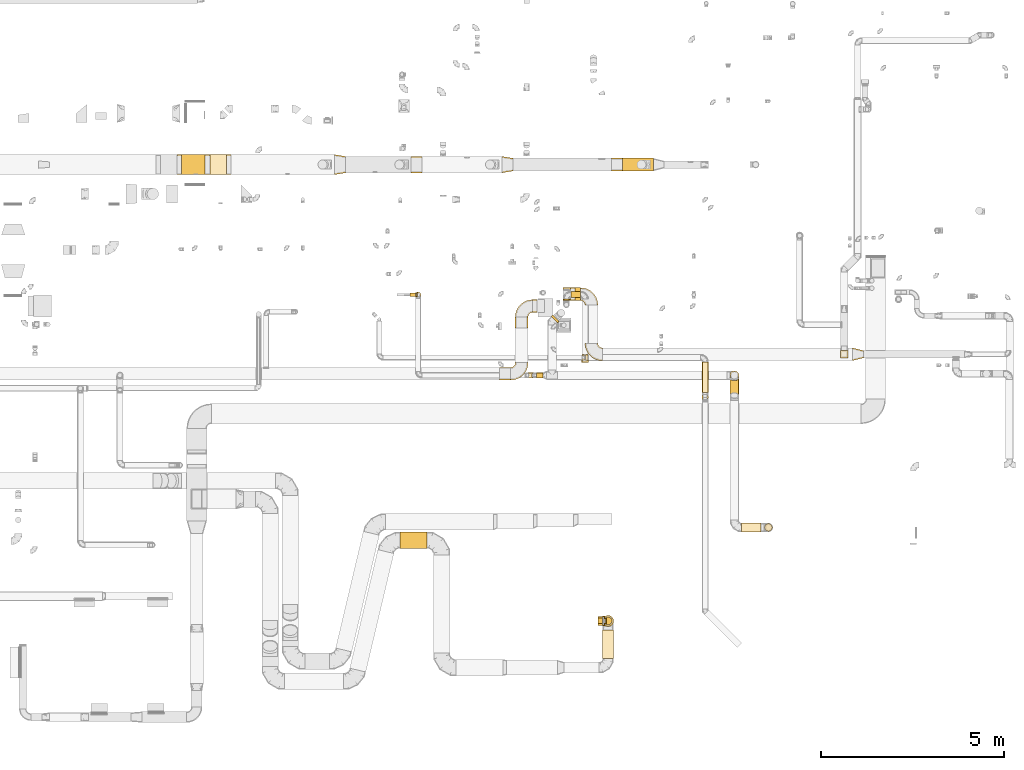
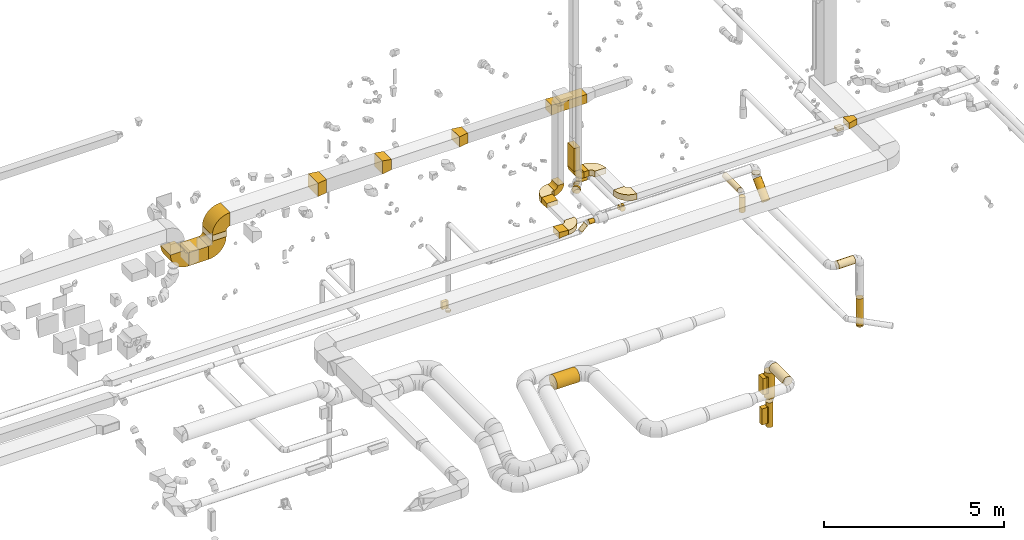
# One storey, part 8 of 97: 49 coverings.
"""IFC2X3 building model written with IfcOpenShell, lengths in millimetres."""

from ifc_helpers import new_model, entity, si_unit, converted_unit, derived_unit, direction, frame, frame_2d, origin, origin_2d_with_axis, place, context, subcontext, project, spatial, polyline, circle_curve, parameter, trimmed, segment, composite_curve, rectangle, circle, outline, extrude, element, save


model = new_model("IFC2X3")

# Units and contexts
model_context = context("Model", 3, precision=0.01, world=origin(), true_north=direction((6.12303176911189e-17, 1.0)))
body_context = subcontext(model_context, "Body", "Model", "MODEL_VIEW")
ifc_project = project(units=[si_unit("LENGTHUNIT", "METRE", prefix="MILLI"), si_unit("AREAUNIT", "SQUARE_METRE"), si_unit("VOLUMEUNIT", "CUBIC_METRE"), converted_unit("PLANEANGLEUNIT", "DEGREE", entity("IfcRatioMeasure", 0.0174532925199433), si_unit("PLANEANGLEUNIT", "RADIAN"), dimensions=[0, 0, 0, 0, 0, 0, 0]), si_unit("MASSUNIT", "GRAM", prefix="KILO"), derived_unit("MASSDENSITYUNIT", [(si_unit("MASSUNIT", "GRAM", prefix="KILO"), 1), (si_unit("LENGTHUNIT", "METRE"), -3)]), derived_unit("MOMENTOFINERTIAUNIT", [(si_unit("LENGTHUNIT", "METRE"), 4)]), si_unit("TIMEUNIT", "SECOND"), si_unit("FREQUENCYUNIT", "HERTZ"), si_unit("THERMODYNAMICTEMPERATUREUNIT", "DEGREE_CELSIUS"), derived_unit("THERMALTRANSMITTANCEUNIT", [(si_unit("MASSUNIT", "GRAM", prefix="KILO"), 1), (si_unit("THERMODYNAMICTEMPERATUREUNIT", "KELVIN"), -1), (si_unit("TIMEUNIT", "SECOND"), -3)]), derived_unit("VOLUMETRICFLOWRATEUNIT", [(si_unit("LENGTHUNIT", "METRE"), 3), (si_unit("TIMEUNIT", "SECOND"), -1)]), derived_unit("MASSFLOWRATEUNIT", [(si_unit("MASSUNIT", "GRAM", prefix="KILO"), 1), (si_unit("TIMEUNIT", "SECOND"), -1)]), derived_unit("ROTATIONALFREQUENCYUNIT", [(si_unit("TIMEUNIT", "SECOND"), -1)]), si_unit("ELECTRICCURRENTUNIT", "AMPERE"), si_unit("ELECTRICVOLTAGEUNIT", "VOLT"), si_unit("POWERUNIT", "WATT"), si_unit("FORCEUNIT", "NEWTON", prefix="KILO"), si_unit("ILLUMINANCEUNIT", "LUX"), si_unit("LUMINOUSFLUXUNIT", "LUMEN"), si_unit("LUMINOUSINTENSITYUNIT", "CANDELA"), derived_unit("USERDEFINED", [(si_unit("MASSUNIT", "GRAM", prefix="KILO"), -1), (si_unit("LENGTHUNIT", "METRE"), -2), (si_unit("TIMEUNIT", "SECOND"), 3), (si_unit("LUMINOUSFLUXUNIT", "LUMEN"), 1)]), derived_unit("LINEARVELOCITYUNIT", [(si_unit("LENGTHUNIT", "METRE"), 1), (si_unit("TIMEUNIT", "SECOND"), -1)]), si_unit("PRESSUREUNIT", "PASCAL"), derived_unit("USERDEFINED", [(si_unit("LENGTHUNIT", "METRE"), -2), (si_unit("MASSUNIT", "GRAM", prefix="KILO"), 1), (si_unit("TIMEUNIT", "SECOND"), -2)]), derived_unit("LINEARFORCEUNIT", [(si_unit("MASSUNIT", "GRAM", prefix="KILO"), 1), (si_unit("LENGTHUNIT", "METRE"), 1), (si_unit("TIMEUNIT", "SECOND"), -2), (si_unit("LENGTHUNIT", "METRE"), -1)]), derived_unit("PLANARFORCEUNIT", [(si_unit("MASSUNIT", "GRAM", prefix="KILO"), 1), (si_unit("LENGTHUNIT", "METRE"), 1), (si_unit("TIMEUNIT", "SECOND"), -2), (si_unit("LENGTHUNIT", "METRE"), -2)])], contexts=[model_context])

# Site, building, storey
site_placement = place(None, origin())
site = spatial("IfcSite", under=ifc_project, at=site_placement, CompositionType="ELEMENT")
building_placement = place(site_placement, origin())
building = spatial("IfcBuilding", under=site, at=building_placement, CompositionType="ELEMENT")
storey_placement = place(building_placement, frame((0.0, 0.0, -4900.0)))
storey = spatial("IfcBuildingStorey", under=building, at=storey_placement, CompositionType="ELEMENT", Elevation=-4900.0)

# Coverings
covering_1_placement = place(storey_placement, frame((55013.15, 4871.73, 2723.4)))
element("IfcCovering", 1, at=covering_1_placement, inside=storey, PredefinedType="INSULATION", context=body_context, shape_type="SweptSolid", body=[
    extrude(circle(Radius=225.0, at=origin_2d_with_axis()), frame((0.0, 226.6, 226.6), z_axis=(1.0, 0.0, 0.0), x_axis=(0.0, 1.0, 0.0)), (0.0, 0.0, 1.0), 730.830177170377),
])
covering_2_placement = place(storey_placement, frame((60537.54, 1876.52, 2798.4)))
element("IfcCovering", 2, at=covering_2_placement, inside=storey, PredefinedType="INSULATION", context=body_context, shape_type="SweptSolid", body=[
    extrude(circle(Radius=150.0, at=origin_2d_with_axis()), frame((151.6, 0.0, 151.6), z_axis=(0.0, 1.0, 0.0), x_axis=(-1.0, 0.0, 0.0)), (0.0, -1.34405375717961e-09, 1.0), 771.024518339497),
])
covering_3_placement = place(storey_placement, frame((60582.54, 2790.95, 822.36)))
element("IfcCovering", 3, at=covering_3_placement, inside=storey, PredefinedType="INSULATION", context=body_context, shape_type="SweptSolid", body=[
    extrude(circle(Radius=105.0, at=origin_2d_with_axis()), frame((106.6, 106.6, 0.0), z_axis=(0.0, 0.0, 1.0), x_axis=(-1.0, 0.0, 0.0)), (0.0, 0.0, 1.0), 839.999998963608),
])
covering_4_placement = place(storey_placement, frame((60537.54, 2745.95, 1816.36)))
element("IfcCovering", 4, at=covering_4_placement, inside=storey, PredefinedType="INSULATION", context=body_context, shape_type="SweptSolid", body=[
    extrude(outline(polyline([(-19.58, -148.72), (19.58, -148.72), (57.4, -138.58), (91.31, -119.0), (119.0, -91.31), (138.58, -57.4), (148.72, -19.58), (148.72, 19.58), (138.58, 57.4), (119.0, 91.31), (91.31, 119.0), (57.4, 138.58), (19.58, 148.72), (-19.58, 148.72), (-57.4, 138.58), (-91.31, 119.0), (-119.0, 91.31), (-138.58, 57.4), (-148.72, 19.58), (-148.72, -19.58), (-138.58, -57.4), (-119.0, -91.31), (-91.31, -119.0), (-57.4, -138.58), (-19.58, -148.72)])), frame((151.6, 151.6, 0.0), z_axis=(0.0, -1.75949613054488e-09, 1.0), x_axis=(0.130526192220057, -0.99144486137381, -1.74444892770835e-09)), (0.0, 0.0, 1.0), 883.639712944482),
])
covering_5_placement = place(storey_placement, frame((60414.13, 2772.54, 2025.0)))
element("IfcCovering", 5, at=covering_5_placement, inside=storey, PredefinedType="INSULATION", context=body_context, shape_type="SweptSolid", body=[
    extrude(rectangle(XDim=129.999999999996, YDim=250.000000000001, at=origin_2d_with_axis()), frame((65.0, 125.0, 0.0), z_axis=(0.0, 0.0, 1.0), x_axis=(-1.0, 0.0, 0.0)), (0.0, 0.0, 1.0), 550.0),
])
covering_6_placement = place(storey_placement, frame((60414.13, 2822.54, 975.0)))
element("IfcCovering", 6, at=covering_6_placement, inside=storey, PredefinedType="INSULATION", context=body_context, shape_type="SweptSolid", body=[
    extrude(rectangle(XDim=174.999999999995, YDim=150.000000000001, at=origin_2d_with_axis()), frame((87.5, 75.0, 0.0), z_axis=(0.0, 0.0, 1.0), x_axis=(-1.0, 0.0, 0.0)), (0.0, 0.0, 1.0), 550.000000000001),
])
covering_7_placement = place(storey_placement, frame((60544.13, 2772.54, 2025.0)))
element("IfcCovering", 7, at=covering_7_placement, inside=storey, PredefinedType="INSULATION", context=body_context, shape_type="SweptSolid", body=[
    extrude(rectangle(XDim=250.000000000001, YDim=51.0960000000016, at=origin_2d_with_axis()), frame((25.55, 125.0, 0.0), z_axis=(0.0, 0.0, 1.0), x_axis=(0.0, -1.0, 0.0)), (0.0, 0.0, 1.0), 550.0),
])
covering_8_placement = place(storey_placement, frame((60589.13, 2822.54, 975.0)))
element("IfcCovering", 8, at=covering_8_placement, inside=storey, PredefinedType="INSULATION", context=body_context, shape_type="SweptSolid", body=[
    extrude(rectangle(XDim=150.000000000001, YDim=51.0960000000102, at=origin_2d_with_axis()), frame((25.55, 75.0, 0.0), z_axis=(0.0, 0.0, 1.0), x_axis=(0.0, -1.0, 0.0)), (0.0, 0.0, 1.0), 550.0),
])
covering_9_placement = place(storey_placement, frame((59130.61, 11025.85, 4223.4)))
element("IfcCovering", 9, at=covering_9_placement, inside=storey, PredefinedType="INSULATION", context=body_context, shape_type="SweptSolid", body=[
    extrude(circle(Radius=125.0, at=origin_2d_with_axis()), frame((89.98, 89.98, 126.6), z_axis=(0.707106781186531, 0.707106781186564, 0.0), x_axis=(-0.707106781186564, 0.707106781186531, 0.0)), (0.0, 0.0, 1.0), 66.3677979742427),
])
covering_10_placement = place(storey_placement, frame((58733.86, 9522.39, 4273.4)))
element("IfcCovering", 10, at=covering_10_placement, inside=storey, PredefinedType="INSULATION", context=body_context, shape_type="SweptSolid", body=[
    extrude(circle(Radius=75.0, at=origin_2d_with_axis()), frame((0.0, 76.6, 76.6), z_axis=(1.0, 0.0, 0.0), x_axis=(0.0, 1.0, 0.0)), (0.0, 0.0, 1.0), 178.14982376268),
])
covering_11_placement = place(storey_placement, frame((58432.1, 9522.39, 4089.66)))
element("IfcCovering", 11, at=covering_11_placement, inside=storey, PredefinedType="INSULATION", context=body_context, shape_type="SweptSolid", body=[
    extrude(circle(Radius=75.0, at=origin_2d_with_axis()), frame((54.63, 76.6, 54.63), z_axis=(0.707106781186546, 0.0, 0.707106781186549), x_axis=(0.0, -1.0, 0.0)), (0.0, 0.0, 1.0), 249.497474683053),
])
covering_12_placement = place(storey_placement, frame((55427.32, 11719.57, 1125.0)))
element("IfcCovering", 12, at=covering_12_placement, inside=storey, PredefinedType="INSULATION", context=body_context, shape_type="SweptSolid", body=[
    extrude(circle(Radius=75.0, at=origin_2d_with_axis()), frame((76.6, 76.6, 0.0)), (0.0, 0.0, 1.0), 50.0000000000016),
])
covering_13_placement = place(storey_placement, frame((55283.91, 11746.17, 1275.0)))
element("IfcCovering", 13, at=covering_13_placement, inside=storey, PredefinedType="INSULATION", context=body_context, shape_type="SweptSolid", body=[
    extrude(rectangle(XDim=149.999999999992, YDim=99.9999999999989, at=origin_2d_with_axis()), frame((75.0, 50.0, 0.0), z_axis=(0.0, 0.0, 1.0), x_axis=(-1.0, 0.0, 0.0)), (0.0, 0.0, 1.0), 249.999999999999),
])
covering_14_placement = place(storey_placement, frame((59780.69, 11639.2, 4250.0)))
element("IfcCovering", 14, at=covering_14_placement, inside=storey, PredefinedType="INSULATION", context=body_context, shape_type="SweptSolid", body=[
    extrude(rectangle(XDim=154.584400000159, YDim=349.999999999998, at=origin_2d_with_axis()), frame((77.29, 175.0, 0.0), z_axis=(0.0, 0.0, 1.0), x_axis=(-1.0, 0.0, 0.0)), (0.0, 0.0, 1.0), 200.0),
])
covering_15_placement = place(storey_placement, frame((67355.27, 9999.06, 4250.0)))
element("IfcCovering", 15, at=covering_15_placement, inside=storey, PredefinedType="INSULATION", context=body_context, shape_type="SweptSolid", body=[
    extrude(outline(polyline([(-187.97, -133.39), (121.27, -133.39), (169.77, 60.63), (-103.08, 206.16), (-187.97, -133.39)])), frame((150.0, 175.0, 0.0), z_axis=(0.0, 0.0, 1.0), x_axis=(0.970142500145381, 0.242535625036135, 0.0)), (0.0, 0.0, 1.0), 200.0),
])
covering_16_placement = place(storey_placement, frame((67029.73, 10074.06, 4225.0)))
element("IfcCovering", 16, at=covering_16_placement, inside=storey, PredefinedType="INSULATION", context=body_context, shape_type="SweptSolid", body=[
    extrude(rectangle(XDim=200.000000000002, YDim=200.000000000007, at=origin_2d_with_axis()), frame((100.0, 100.0, 0.0), z_axis=(0.0, 0.0, 1.0), x_axis=(0.0, -1.0, 0.0)), (0.0, 0.0, 1.0), 30.0000000000121),
])
covering_17_placement = place(storey_placement, frame((67029.73, 10074.06, 4255.0)))
element("IfcCovering", 17, at=covering_17_placement, inside=storey, PredefinedType="INSULATION", context=body_context, shape_type="SweptSolid", body=[
    extrude(rectangle(XDim=200.0, YDim=199.999999999998, at=origin_2d_with_axis()), frame((100.0, 100.0, 0.0), z_axis=(0.0, 0.0, 1.0), x_axis=(0.0, -1.0, 0.0)), (0.0, 0.0, 1.0), 51.096000000006),
])
covering_18_placement = place(storey_placement, frame((59455.69, 11639.2, 4575.0)))
element("IfcCovering", 18, at=covering_18_placement, inside=storey, PredefinedType="INSULATION", context=body_context, shape_type="SweptSolid", body=[
    extrude(rectangle(XDim=200.000000000007, YDim=349.999999999998, at=origin_2d_with_axis()), frame((100.0, 175.0, 0.0)), (0.0, 0.0, 1.0), 775.000000000065),
])
covering_19_placement = place(storey_placement, frame((59460.9, 11649.89, 4025.9)))
element("IfcCovering", 19, at=covering_19_placement, inside=storey, PredefinedType="INSULATION", context=body_context, shape_type="SweptSolid", body=[
    extrude(circle(Radius=87.5, at=origin_2d_with_axis()), frame((89.1, 0.0, 89.1), z_axis=(-2.77012810696596e-07, 1.0, -2.02770838470694e-07), x_axis=(-1.0, -2.77012810696601e-07, 0.0)), (0.0, 0.0, 1.0), 30.9741654758868),
])
covering_20_placement = place(storey_placement, frame((59674.99, 11716.77, 4025.9)))
element("IfcCovering", 20, at=covering_20_placement, inside=storey, PredefinedType="INSULATION", context=body_context, shape_type="SweptSolid", body=[
    extrude(circle(Radius=87.5, at=origin_2d_with_axis()), frame((0.0, 89.1, 89.1), z_axis=(1.0, 0.0, 0.0), x_axis=(0.0, 1.0, 0.0)), (0.0, 0.0, 1.0), 262.660841981736),
])
covering_21_placement = place(storey_placement, frame((63249.01, 9126.07, 4025.9)))
element("IfcCovering", 21, at=covering_21_placement, inside=storey, PredefinedType="INSULATION", context=body_context, shape_type="SweptSolid", body=[
    extrude(circle(Radius=87.5, at=origin_2d_with_axis()), frame((89.1, 0.0, 89.1), z_axis=(0.0, 1.0, 0.0), x_axis=(1.0, 0.0, 0.0)), (0.0, 0.0, 1.0), 832.512489999981),
])
covering_22_placement = place(storey_placement, frame((63249.01, 8911.97, 3475.0)))
element("IfcCovering", 22, at=covering_22_placement, inside=storey, PredefinedType="INSULATION", context=body_context, shape_type="SweptSolid", body=[
    extrude(circle(Radius=87.5, at=origin_2d_with_axis()), frame((89.1, 89.1, 0.0)), (0.0, 0.0, 1.0), 514.999994350737),
])
covering_23_placement = place(storey_placement, frame((58154.81, 10887.87, 4225.0)))
element("IfcCovering", 23, at=covering_23_placement, inside=storey, PredefinedType="INSULATION", context=body_context, shape_type="SweptSolid", body=[
    extrude(outline(polyline([(-157.79, -87.2), (143.25, -87.2), (155.71, 62.28), (-141.18, 112.11), (-157.79, -87.2)])), frame((0.0, 150.0, 100.0), z_axis=(1.0, 0.0, 0.0), x_axis=(0.0, -0.996545758244883, -0.0830454798537022)), (0.0, 0.0, 1.0), 350.000000000007),
])
covering_24_placement = place(storey_placement, frame((57729.81, 9468.15, 4225.0)))
element("IfcCovering", 24, at=covering_24_placement, inside=storey, PredefinedType="INSULATION", context=body_context, shape_type="SweptSolid", body=[
    extrude(outline(polyline([(-143.25, -87.2), (157.79, -87.2), (141.18, 112.11), (-155.71, 62.28), (-143.25, -87.2)])), frame((150.0, 0.0, 100.0), z_axis=(0.0, 1.0, 0.0), x_axis=(-0.996545758244883, 0.0, -0.0830454798537045)), (0.0, 0.0, 1.0), 349.999999999998),
])
covering_25_placement = place(storey_placement, frame((59980.15, 10006.99, 4038.4)))
element("IfcCovering", 25, at=covering_25_placement, inside=storey, PredefinedType="INSULATION", context=body_context, shape_type="SweptSolid", body=[
    extrude(circle(Radius=75.0, at=origin_2d_with_axis()), frame((0.0, 76.6, 76.6), z_axis=(1.0, 0.0, 0.0), x_axis=(0.0, -1.0, 0.0)), (0.0, 0.0, 1.0), 51.0960000000709),
])
covering_26_placement = place(storey_placement, frame((60068.75, 9994.49, 4025.9)))
element("IfcCovering", 26, at=covering_26_placement, inside=storey, PredefinedType="INSULATION", context=body_context, shape_type="SweptSolid", body=[
    extrude(circle(Radius=87.5, at=origin_2d_with_axis()), frame((0.0, 89.1, 89.1), z_axis=(1.0, 0.0, 0.0), x_axis=(0.0, 1.0, 0.0)), (0.0, 0.0, 1.0), 76.4039999999954),
])
covering_27_placement = place(storey_placement, frame((59973.56, 9955.87, 4025.9)))
element("IfcCovering", 27, at=covering_27_placement, inside=storey, PredefinedType="INSULATION", context=body_context, shape_type="SweptSolid", body=[
    extrude(circle(Radius=87.5, at=origin_2d_with_axis()), frame((89.1, 0.0, 89.1), z_axis=(0.0, 1.0, 0.0), x_axis=(1.0, 0.0, 0.0)), (0.0, 0.0, 1.0), 50.0000000000016),
])
covering_28_placement = place(storey_placement, frame((64007.19, 9472.39, 4142.84)))
element("IfcCovering", 28, at=covering_28_placement, inside=storey, PredefinedType="INSULATION", context=body_context, shape_type="SweptSolid", body=[
    extrude(circle(Radius=125.0, at=origin_2d_with_axis()), frame((126.6, 126.6, 0.0), z_axis=(0.0, 0.0, 1.0), x_axis=(0.0, -1.0, 0.0)), (0.0, 0.0, 1.0), 7.15728752538508),
])
covering_29_placement = place(storey_placement, frame((49052.19, 15073.96, 2925.0)))
element("IfcCovering", 29, at=covering_29_placement, inside=storey, PredefinedType="INSULATION", context=body_context, shape_type="SweptSolid", body=[
    extrude(rectangle(XDim=642.936890000042, YDim=550.000000000001, at=origin_2d_with_axis()), frame((321.47, 275.0, 0.0)), (0.0, 0.0, 1.0), 450.0),
])
covering_30_placement = place(storey_placement, frame((49820.13, 15073.96, 3500.0)))
element("IfcCovering", 30, at=covering_30_placement, inside=storey, PredefinedType="INSULATION", context=body_context, shape_type="SweptSolid", body=[
    extrude(rectangle(XDim=450.000000000002, YDim=550.000000000001, at=origin_2d_with_axis()), frame((225.0, 275.0, 0.0), z_axis=(0.0, 0.0, 1.0), x_axis=(-1.0, 0.0, 0.0)), (0.0, 0.0, 1.0), 200.000000000009),
])
covering_31_placement = place(storey_placement, frame((55315.5, 15123.96, 3825.0)))
element("IfcCovering", 31, at=covering_31_placement, inside=storey, PredefinedType="INSULATION", context=body_context, shape_type="SweptSolid", body=[
    extrude(outline(polyline([(-184.95, -197.28), (119.19, -197.28), (176.73, 147.96), (-110.97, 246.6), (-184.95, -197.28)])), frame((150.0, 0.0, 225.0), z_axis=(0.0, 1.0, 0.0), x_axis=(0.986393923832149, 0.0, -0.164398987305325)), (0.0, 0.0, 1.0), 450.000000000002),
])
covering_32_placement = place(storey_placement, frame((57790.67, 15123.96, 3875.0)))
element("IfcCovering", 32, at=covering_32_placement, inside=storey, PredefinedType="INSULATION", context=body_context, shape_type="SweptSolid", body=[
    extrude(outline(polyline([(-184.95, -197.28), (119.19, -197.28), (176.73, 147.96), (-110.97, 246.6), (-184.95, -197.28)])), frame((150.0, 225.0, 0.0), z_axis=(0.0, 0.0, 1.0), x_axis=(0.986393923832178, 0.164398987305152, 0.0)), (0.0, 0.0, 1.0), 350.0),
])
covering_33_placement = place(storey_placement, frame((61080.93, 15173.96, 3900.0)))
element("IfcCovering", 33, at=covering_33_placement, inside=storey, PredefinedType="INSULATION", context=body_context, shape_type="SweptSolid", body=[
    extrude(rectangle(XDim=839.433055887242, YDim=349.999999999998, at=origin_2d_with_axis()), frame((419.72, 175.0, 0.0)), (0.0, 0.0, 1.0), 300.0),
])
covering_34_placement = place(storey_placement, frame((60780.93, 15173.96, 3875.0)))
element("IfcCovering", 34, at=covering_34_placement, inside=storey, PredefinedType="INSULATION", context=body_context, shape_type="SweptSolid", body=[
    extrude(outline(polyline([(-137.03, -161.94), (164.01, -161.94), (134.95, 186.85), (-161.94, 137.03), (-137.03, -161.94)])), frame((150.0, 0.0, 175.0), z_axis=(0.0, 1.0, 0.0), x_axis=(-0.996545758244883, 0.0, -0.0830454798537045)), (0.0, 0.0, 1.0), 349.999999999998),
])
covering_35_placement = place(storey_placement, frame((53221.17, 15073.96, 3825.0)))
element("IfcCovering", 35, at=covering_35_placement, inside=storey, PredefinedType="INSULATION", context=body_context, shape_type="SweptSolid", body=[
    extrude(outline(polyline([(-110.97, -246.6), (193.17, -246.6), (102.75, 295.92), (-184.95, 197.28), (-110.97, -246.6)])), frame((150.0, 275.0, 0.0), z_axis=(0.0, 0.0, 1.0), x_axis=(-0.986393923832109, 0.164398987305567, 0.0)), (0.0, 0.0, 1.0), 450.0),
])
covering_36_placement = place(storey_placement, frame((64333.78, 5321.85, 3323.4)))
element("IfcCovering", 36, at=covering_36_placement, inside=storey, PredefinedType="INSULATION", context=body_context, shape_type="SweptSolid", body=[
    extrude(circle(Radius=125.0, at=origin_2d_with_axis()), frame((0.0, 126.6, 126.6), z_axis=(1.0, 0.0, 0.0), x_axis=(0.0, 1.0, 0.0)), (0.0, 0.0, 1.0), 529.688711010026),
])
covering_37_placement = place(storey_placement, frame((64956.87, 5341.85, 1200.01)))
element("IfcCovering", 37, at=covering_37_placement, inside=storey, PredefinedType="INSULATION", context=body_context, shape_type="SweptSolid", body=[
    extrude(circle(Radius=105.0, at=origin_2d_with_axis()), frame((106.6, 106.6, 0.0), z_axis=(0.0, 0.0, 1.0), x_axis=(0.0, -1.0, 0.0)), (0.0, 0.0, 1.0), 910.0),
])
covering_38_placement = place(storey_placement, frame((64956.87, 5341.85, 1150.01)))
element("IfcCovering", 38, at=covering_38_placement, inside=storey, PredefinedType="INSULATION", context=body_context, shape_type="SweptSolid", body=[
    extrude(circle(Radius=105.0, at=origin_2d_with_axis()), frame((106.6, 106.6, 0.0), z_axis=(0.0, 0.0, 1.0), x_axis=(0.0, -1.0, 0.0)), (0.0, 0.0, 1.0), 50.0000000000016),
])
covering_39_placement = place(storey_placement, frame((64007.19, 8957.58, 3418.6)))
element("IfcCovering", 39, at=covering_39_placement, inside=storey, PredefinedType="INSULATION", context=body_context, shape_type="SweptSolid", body=[
    extrude(circle(Radius=125.0, at=origin_2d_with_axis()), frame((126.6, 89.98, 89.98), z_axis=(0.0, 0.707106781186548, 0.707106781186547), x_axis=(-1.0, 0.0, 0.0)), (0.0, 0.0, 1.0), 696.984848098374),
])
covering_40_placement = place(storey_placement, frame((55433.91, 11746.17, 1275.0)))
element("IfcCovering", 40, at=covering_40_placement, inside=storey, PredefinedType="INSULATION", context=body_context, shape_type="SweptSolid", body=[
    extrude(rectangle(XDim=99.9999999999989, YDim=51.3610000000106, at=origin_2d_with_axis()), frame((25.68, 50.0, 0.0), z_axis=(0.0, 0.0, 1.0), x_axis=(0.0, -1.0, 0.0)), (0.0, 0.0, 1.0), 250.0),
])
covering_41_placement = place(storey_placement, frame((59933.68, 11512.61, 4250.0)))
element("IfcCovering", 41, at=covering_41_placement, inside=storey, PredefinedType="INSULATION", context=body_context, shape_type="SweptSolid", body=[
    extrude(outline(composite_curve([segment(polyline([(-150.0, 25.0), (-150.0, -325.0)]), True, "CONTINUOUS"), segment(trimmed(circle_curve(frame_2d((-150.0, 150.0), x_axis=(1.0, 0.0)), 475.0), [parameter(270.0)], [parameter(0.0)], True, "PARAMETER"), True, "CONTINUOUS"), segment(polyline([(325.0, 150.0), (-25.0, 150.0)]), True, "CONTINUOUS"), segment(trimmed(circle_curve(frame_2d((-150.0, 150.0), x_axis=(1.0, 0.0)), 125.0), [parameter(270.0)], [parameter(360.0)], True, "PARAMETER"), False, "CONTINUOUS")], self_intersect=False)), frame((151.6, 151.6, 0.0), z_axis=(0.0, 0.0, -1.0), x_axis=(1.0, 0.0, 0.0)), (0.0, 0.0, -1.0), 200.0),
])
covering_42_placement = place(storey_placement, frame((60058.68, 9997.47, 4250.0)))
element("IfcCovering", 42, at=covering_42_placement, inside=storey, PredefinedType="INSULATION", context=body_context, shape_type="SweptSolid", body=[
    extrude(outline(composite_curve([segment(polyline([(-150.0, 25.0), (-150.0, -325.0)]), True, "CONTINUOUS"), segment(trimmed(circle_curve(frame_2d((-150.0, 150.0), x_axis=(1.0, 0.0)), 475.0), [parameter(270.0)], [parameter(0.0)], True, "PARAMETER"), True, "CONTINUOUS"), segment(polyline([(325.0, 150.0), (-25.0, 150.0)]), True, "CONTINUOUS"), segment(trimmed(circle_curve(frame_2d((-150.0, 150.0), x_axis=(1.0, 0.0)), 125.0), [parameter(270.0)], [parameter(360.0)], True, "PARAMETER"), False, "CONTINUOUS")], self_intersect=False)), frame((326.6, 326.6, 0.0), z_axis=(0.0, 0.0, -1.0), x_axis=(-1.0, 0.0, 0.0)), (0.0, 0.0, -1.0), 200.0),
])
covering_43_placement = place(storey_placement, frame((59454.09, 11639.2, 4248.4)))
element("IfcCovering", 43, at=covering_43_placement, inside=storey, PredefinedType="INSULATION", context=body_context, shape_type="SweptSolid", body=[
    extrude(outline(composite_curve([segment(polyline([(-112.5, -12.5), (-112.5, -212.5)]), True, "CONTINUOUS"), segment(trimmed(circle_curve(frame_2d((-112.5, 112.5), x_axis=(1.0, 0.0)), 325.0), [parameter(270.0)], [parameter(0.0)], True, "PARAMETER"), True, "CONTINUOUS"), segment(polyline([(212.5, 112.5), (12.5, 112.5)]), True, "CONTINUOUS"), segment(trimmed(circle_curve(frame_2d((-112.5, 112.5), x_axis=(1.0, 0.0)), 125.0), [parameter(270.0)], [parameter(360.0)], True, "PARAMETER"), False, "CONTINUOUS")], self_intersect=False)), frame((214.1, 0.0, 214.1), z_axis=(0.0, -1.0, 0.0), x_axis=(0.0, 0.0, -1.0)), (0.0, 0.0, -1.0), 349.999999999998),
])
covering_44_placement = place(storey_placement, frame((58153.22, 11186.27, 4225.0)))
element("IfcCovering", 44, at=covering_44_placement, inside=storey, PredefinedType="INSULATION", context=body_context, shape_type="SweptSolid", body=[
    extrude(outline(composite_curve([segment(polyline([(-150.0, 25.0), (-150.0, -325.0)]), True, "CONTINUOUS"), segment(trimmed(circle_curve(frame_2d((-150.0, 150.0), x_axis=(1.0, 0.0)), 475.0), [parameter(270.0)], [parameter(0.0)], True, "PARAMETER"), True, "CONTINUOUS"), segment(polyline([(325.0, 150.0), (-25.0, 150.0)]), True, "CONTINUOUS"), segment(trimmed(circle_curve(frame_2d((-150.0, 150.0), x_axis=(1.0, 0.0)), 125.0), [parameter(270.0)], [parameter(360.0)], True, "PARAMETER"), False, "CONTINUOUS")], self_intersect=False)), frame((326.6, 151.6, 0.0), z_axis=(0.0, 0.0, -1.0), x_axis=(0.0, 1.0, 0.0)), (0.0, 0.0, -1.0), 200.0),
])
covering_45_placement = place(storey_placement, frame((58628.22, 11312.87, 4223.4)))
element("IfcCovering", 45, at=covering_45_placement, inside=storey, PredefinedType="INSULATION", context=body_context, shape_type="SweptSolid", body=[
    extrude(outline(composite_curve([segment(polyline([(12.5, -112.5), (212.5, -112.5)]), True, "CONTINUOUS"), segment(trimmed(circle_curve(frame_2d((-112.5, -112.5), x_axis=(0.0, 1.0)), 325.0), [parameter(270.0)], [parameter(0.0)], True, "PARAMETER"), True, "CONTINUOUS"), segment(polyline([(-112.5, 212.5), (-112.5, 12.5)]), True, "CONTINUOUS"), segment(trimmed(circle_curve(frame_2d((-112.5, -112.5), x_axis=(0.0, 1.0)), 125.0), [parameter(270.0)], [parameter(360.0)], True, "PARAMETER"), False, "CONTINUOUS")], self_intersect=False)), frame((114.1, 0.0, 214.1), z_axis=(0.0, 1.0, 0.0), x_axis=(1.0, 0.0, 0.0)), (0.0, 0.0, 1.0), 349.999999999998),
])
covering_46_placement = place(storey_placement, frame((58028.22, 9466.55, 4250.0)))
element("IfcCovering", 46, at=covering_46_placement, inside=storey, PredefinedType="INSULATION", context=body_context, shape_type="SweptSolid", body=[
    extrude(outline(composite_curve([segment(polyline([(-150.0, 25.0), (-150.0, -325.0)]), True, "CONTINUOUS"), segment(trimmed(circle_curve(frame_2d((-150.0, 150.0), x_axis=(1.0, 0.0)), 475.0), [parameter(270.0)], [parameter(0.0)], True, "PARAMETER"), True, "CONTINUOUS"), segment(polyline([(325.0, 150.0), (-25.0, 150.0)]), True, "CONTINUOUS"), segment(trimmed(circle_curve(frame_2d((-150.0, 150.0), x_axis=(1.0, 0.0)), 125.0), [parameter(270.0)], [parameter(360.0)], True, "PARAMETER"), False, "CONTINUOUS")], self_intersect=False)), frame((151.6, 326.6, 0.0), z_axis=(0.0, 0.0, -1.0), x_axis=(0.0, -1.0, 0.0)), (0.0, 0.0, -1.0), 150.0),
])
covering_47_placement = place(storey_placement, frame((48475.6, 15073.96, 2923.4)))
element("IfcCovering", 47, at=covering_47_placement, inside=storey, PredefinedType="INSULATION", context=body_context, shape_type="SweptSolid", body=[
    extrude(outline(composite_curve([segment(polyline([(-50.0, -175.0), (400.0, -175.0)]), True, "CONTINUOUS"), segment(trimmed(circle_curve(frame_2d((-175.0, -175.0), x_axis=(0.0, 1.0)), 575.0), [parameter(270.0)], [parameter(0.0)], True, "PARAMETER"), True, "CONTINUOUS"), segment(polyline([(-175.0, 400.0), (-175.0, -50.0)]), True, "CONTINUOUS"), segment(trimmed(circle_curve(frame_2d((-175.0, -175.0), x_axis=(0.0, 1.0)), 125.0), [parameter(270.0)], [parameter(360.0)], True, "PARAMETER"), False, "CONTINUOUS")], self_intersect=False)), frame((401.6, 0.0, 401.6), z_axis=(0.0, 1.0, 0.0), x_axis=(0.0, 0.0, -1.0)), (0.0, 0.0, 1.0), 550.000000000001),
])
covering_48_placement = place(storey_placement, frame((49693.53, 15073.96, 2923.4)))
element("IfcCovering", 48, at=covering_48_placement, inside=storey, PredefinedType="INSULATION", context=body_context, shape_type="SweptSolid", body=[
    extrude(outline(composite_curve([segment(polyline([(-50.0, -175.0), (400.0, -175.0)]), True, "CONTINUOUS"), segment(trimmed(circle_curve(frame_2d((-175.0, -175.0), x_axis=(0.0, 1.0)), 575.0), [parameter(270.0)], [parameter(0.0)], True, "PARAMETER"), True, "CONTINUOUS"), segment(polyline([(-175.0, 400.0), (-175.0, -50.0)]), True, "CONTINUOUS"), segment(trimmed(circle_curve(frame_2d((-175.0, -175.0), x_axis=(0.0, 1.0)), 125.0), [parameter(270.0)], [parameter(360.0)], True, "PARAMETER"), False, "CONTINUOUS")], self_intersect=False)), frame((176.6, 0.0, 401.6), z_axis=(0.0, 1.0, 0.0), x_axis=(1.0, 0.0, 0.0)), (0.0, 0.0, 1.0), 550.000000000001),
])
covering_49_placement = place(storey_placement, frame((49818.53, 15073.96, 3698.4)))
element("IfcCovering", 49, at=covering_49_placement, inside=storey, PredefinedType="INSULATION", context=body_context, shape_type="SweptSolid", body=[
    extrude(outline(composite_curve([segment(polyline([(-175.0, 50.0), (-175.0, -400.0)]), True, "CONTINUOUS"), segment(trimmed(circle_curve(frame_2d((-175.0, 175.0), x_axis=(1.0, 0.0)), 575.0), [parameter(270.0)], [parameter(0.0)], True, "PARAMETER"), True, "CONTINUOUS"), segment(polyline([(400.0, 175.0), (-50.0, 175.0)]), True, "CONTINUOUS"), segment(trimmed(circle_curve(frame_2d((-175.0, 175.0), x_axis=(1.0, 0.0)), 125.0), [parameter(270.0)], [parameter(360.0)], True, "PARAMETER"), False, "CONTINUOUS")], self_intersect=False)), frame((401.6, 0.0, 176.6), z_axis=(0.0, -1.0, 0.0), x_axis=(-1.0, 0.0, 0.0)), (0.0, 0.0, -1.0), 550.000000000001),
])

save(model, "model.ifc")
